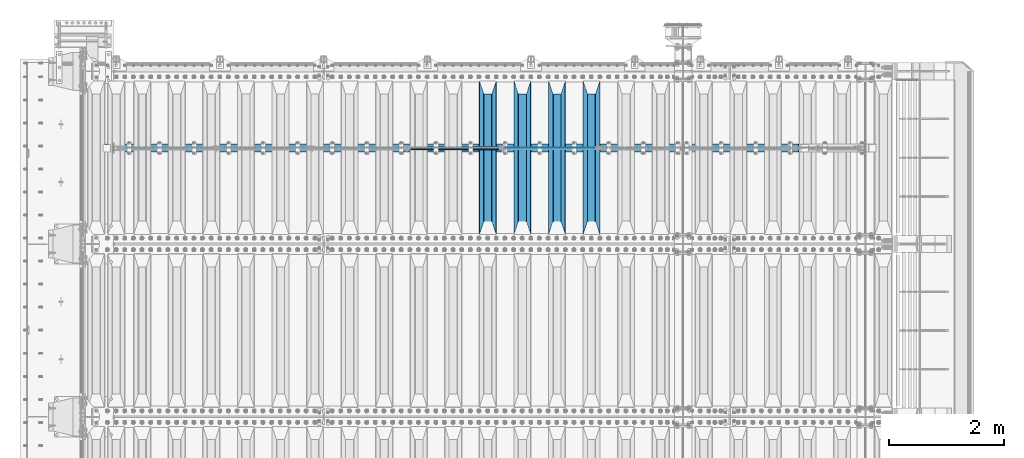
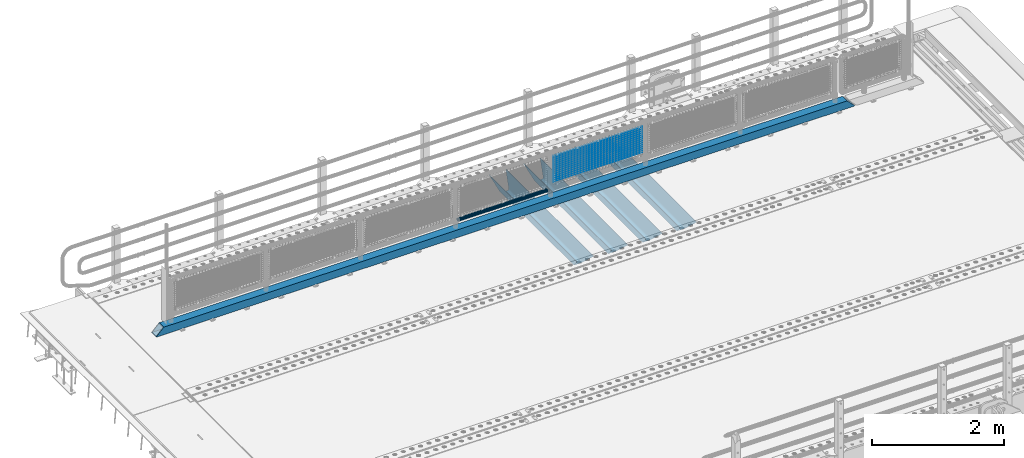
# One storey, part 113 of 219: 20 beams.
"""IFC2X3 building model written with IfcOpenShell, lengths in millimetres."""

from ifc_helpers import new_model, si_unit, frame, origin_with_axes, place, context, subcontext, project, spatial, faceted_brep, material, type_object, element, save


model = new_model("IFC2X3")

# Units and contexts
model_context = context("Model", 3, precision=1e-05, world=origin_with_axes())
body_context = subcontext(model_context, "Body", "Model", "MODEL_VIEW")
ifc_project = project(units=[si_unit("LENGTHUNIT", "METRE", prefix="MILLI"), si_unit("AREAUNIT", "SQUARE_METRE"), si_unit("VOLUMEUNIT", "CUBIC_METRE"), si_unit("MASSUNIT", "GRAM", prefix="KILO"), si_unit("TIMEUNIT", "SECOND"), si_unit("PLANEANGLEUNIT", "RADIAN"), si_unit("SOLIDANGLEUNIT", "STERADIAN"), si_unit("THERMODYNAMICTEMPERATUREUNIT", "DEGREE_CELSIUS"), si_unit("LUMINOUSINTENSITYUNIT", "LUMEN")], contexts=[model_context])

# Site, building, storey
site_placement = place(None, origin_with_axes())
site = spatial("IfcSite", under=ifc_project, at=site_placement, CompositionType="ELEMENT")
building_placement = place(site_placement, origin_with_axes())
building = spatial("IfcBuilding", under=site, at=building_placement, Name="Standard", CompositionType="ELEMENT")
storey_placement = place(building_placement, origin_with_axes())
storey = spatial("IfcBuildingStorey", under=building, at=storey_placement, Name="Undefined", CompositionType="ELEMENT", Elevation=0.0)

# Beams
ifc_material_1 = material(Name="STEEL/S355N")
beam_type_1 = type_object("IfcBeamType", PredefinedType="NOTDEFINED")
beam_1_placement = place(storey_placement, frame((8800.0, 30175.0, -115.0), z_axis=(0.0, 0.0, 1.0), x_axis=(0.0, 1.0, 0.0)))
element("IfcBeam", 1, at=beam_1_placement, inside=storey, type_object=beam_type_1, material=ifc_material_1, context=body_context, shape_type="Brep", body=[
    faceted_brep([(0.0, 150.0, 115.0), (0.0, 143.690000000001, 115.0), (2650.00000000297, 143.690000000001, 115.0), (2650.00000000297, 150.0, 115.0), (2650.00000000297, 142.0595652184, 110.000000003094), (2650.00000000297, 148.3695652184, 110.000000003094), (2441.90079219209, -80.110360073113, -98.0992078077845), (2437.7588105432, -77.5672621345566, -102.241189456673), (2434.06523489747, -74.4080125315541, -105.934765102404), (2430.9108609509, -70.7102721255742, -109.089139048974), (2428.37322971128, -66.5649389910068, -111.626770288588), (2426.51472138055, -62.0739139532889, -113.485278619323), (2425.38102192092, -57.3475956567672, -114.618978078955), (2424.99999999988, -52.5021667386536, -115.0), (2424.99999999988, 52.5021667386536, -115.0), (2425.38102192092, 57.3475956567672, -114.618978078955), (2426.51472138055, 62.0739139532889, -113.485278619323), (2428.37322971128, 66.5649389910068, -111.626770288588), (2430.9108609509, 70.7102721255742, -109.089139048974), (2434.06523489747, 74.4080125315541, -105.934765102404), (2437.7588105432, 77.5672621345566, -102.241189456673), (2441.90079219209, 80.110360073113, -98.0992078077846), (2446.38936140512, 81.9747917625791, -93.6106385947584), (2448.2494850041, 76.2713538057269, -91.7505149957729), (2444.62967112263, 74.7677798626082, -95.3703288772456), (2441.28936334127, 72.7168944282894, -98.710636658607), (2438.31067330439, 70.1691124903828, -101.689326695487), (2435.76682334748, 67.1870637758839, -104.233176652398), (2433.72034654134, 63.8440531834913, -106.279653458539), (2432.22154950042, 60.2222587982342, -107.778450499454), (2431.30727574265, 56.4107117849107, -108.692724257221), (2430.99999999987, 52.5031078186894, -109.0), (2430.99999999987, -52.5031078186894, -109.0), (2431.30727574265, -56.4107117849107, -108.692724257221), (2432.22154950042, -60.2222587982342, -107.778450499454), (2433.72034654134, -63.8440531834913, -106.279653458539), (2435.76682334748, -67.1870637758839, -104.233176652398), (2438.31067330439, -70.1691124903828, -101.689326695487), (2441.28936334127, -72.7168944282894, -98.7106366586071), (2444.62967112263, -74.7677798626082, -95.3703288772457), (2448.2494850041, -76.2713538057269, -91.7505149957729), (2650.00000000297, -142.0595652184, 110.000000003094), (2650.00000000297, -148.3695652184, 110.000000003094), (2446.38936140512, -81.9747917625791, -93.6106385947584), (2650.00000000297, -143.690000000001, 115.0), (2650.00000000297, -150.0, 115.0), (0.0, -143.690000000001, 115.0), (0.0, -150.0, 115.0), (0.0, -148.369565218261, 110.000000002667), (203.610638597427, -81.9747917625791, -93.6106385947584), (208.09920781045, -80.110360073113, -98.0992078077845), (212.241189459342, -77.5672621345566, -102.241189456673), (215.93476510507, -74.4080125315541, -105.934765102404), (219.089139051641, -70.7102721255742, -109.089139048974), (221.626770291256, -66.5649389910068, -111.626770288588), (223.485278621989, -62.0739139532889, -113.485278619323), (224.618978081624, -57.3475956567672, -114.618978078955), (225.000000002663, -52.5021667386536, -115.0), (225.000000002663, 52.5021667386536, -115.0), (224.618978081624, 57.3475956567672, -114.618978078955), (223.485278621989, 62.0739139532889, -113.485278619323), (221.626770291256, 66.5649389910068, -111.626770288588), (219.089139051641, 70.7102721255742, -109.089139048974), (215.93476510507, 74.4080125315541, -105.934765102404), (212.241189459342, 77.5672621345566, -102.241189456673), (208.09920781045, 80.110360073113, -98.0992078077846), (203.610638597427, 81.9747917625791, -93.6106385947584), (0.0, 148.369565218261, 110.000000002667), (0.0, 142.059565218262, 110.000000002667), (201.750514998439, 76.2713538057269, -91.7505149957729), (205.370328879915, 74.7677798626082, -95.3703288772456), (208.710636661275, 72.7168944282894, -98.710636658607), (211.689326698157, 70.1691124903828, -101.689326695487), (214.233176655063, 67.1870637758839, -104.233176652398), (216.279653461206, 63.8440531834913, -106.279653458539), (217.778450502123, 60.2222587982342, -107.778450499454), (218.69272425989, 56.4107117849107, -108.692724257221), (219.00000000267, 52.5031078186894, -109.0), (219.00000000267, -52.5031078186894, -109.0), (218.69272425989, -56.4107117849107, -108.692724257221), (217.778450502123, -60.2222587982342, -107.778450499454), (216.279653461206, -63.8440531834913, -106.279653458539), (214.233176655063, -67.1870637758839, -104.233176652398), (211.689326698157, -70.1691124903828, -101.689326695487), (208.710636661275, -72.7168944282894, -98.7106366586071), (205.370328879915, -74.7677798626082, -95.3703288772457), (201.750514998439, -76.2713538057269, -91.7505149957729), (0.0, -142.059565218262, 110.000000002667)], [[[0, 1, 2, 3]], [[3, 2, 4, 5]], [[6, 7, 8, 9, 10, 11, 12, 13, 14, 15, 16, 17, 18, 19, 20, 21, 22, 5, 4, 23, 24, 25, 26, 27, 28, 29, 30, 31, 32, 33, 34, 35, 36, 37, 38, 39, 40, 41, 42, 43]], [[44, 45, 42, 41]], [[46, 47, 45, 44]], [[43, 42, 45, 47, 48, 49]], [[6, 43, 49, 50]], [[7, 6, 50, 51]], [[8, 7, 51, 52]], [[9, 8, 52, 53]], [[10, 9, 53, 54]], [[11, 10, 54, 55]], [[12, 11, 55, 56]], [[13, 12, 56, 57]], [[14, 13, 57, 58]], [[15, 14, 58, 59]], [[16, 15, 59, 60]], [[17, 16, 60, 61]], [[18, 17, 61, 62]], [[19, 18, 62, 63]], [[20, 19, 63, 64]], [[21, 20, 64, 65]], [[22, 21, 65, 66]], [[0, 3, 5, 22, 66, 67]], [[1, 0, 67, 68]], [[23, 4, 2, 1, 68, 69]], [[24, 23, 69, 70]], [[25, 24, 70, 71]], [[26, 25, 71, 72]], [[27, 26, 72, 73]], [[28, 27, 73, 74]], [[29, 28, 74, 75]], [[30, 29, 75, 76]], [[31, 30, 76, 77]], [[32, 31, 77, 78]], [[33, 32, 78, 79]], [[34, 33, 79, 80]], [[35, 34, 80, 81]], [[36, 35, 81, 82]], [[37, 36, 82, 83]], [[38, 37, 83, 84]], [[39, 38, 84, 85]], [[40, 39, 85, 86]], [[46, 44, 41, 40, 86, 87]], [[47, 46, 87, 48]], [[86, 85, 84, 83, 82, 81, 80, 79, 78, 77, 76, 75, 74, 73, 72, 71, 70, 69, 68, 67, 66, 65, 64, 63, 62, 61, 60, 59, 58, 57, 56, 55, 54, 53, 52, 51, 50, 49, 48, 87]]]),
])
beam_2_placement = place(storey_placement, frame((8200.0, 30175.0, -115.0), z_axis=(0.0, 0.0, 1.0), x_axis=(0.0, 1.0, 0.0)))
element("IfcBeam", 2, at=beam_2_placement, inside=storey, type_object=beam_type_1, material=ifc_material_1, context=body_context, shape_type="Brep", body=[
    faceted_brep([(0.0, 150.0, 115.0), (0.0, 143.690000000001, 115.0), (2650.00000000297, 143.690000000001, 115.0), (2650.00000000297, 150.0, 115.0), (2650.00000000297, 142.0595652184, 110.000000003094), (2650.00000000297, 148.3695652184, 110.000000003094), (2441.90079219209, -80.110360073113, -98.0992078077845), (2437.7588105432, -77.5672621345566, -102.241189456673), (2434.06523489747, -74.4080125315541, -105.934765102404), (2430.9108609509, -70.7102721255742, -109.089139048974), (2428.37322971128, -66.5649389910068, -111.626770288588), (2426.51472138055, -62.0739139532889, -113.485278619323), (2425.38102192092, -57.3475956567672, -114.618978078955), (2424.99999999988, -52.5021667386536, -115.0), (2424.99999999988, 52.5021667386536, -115.0), (2425.38102192092, 57.3475956567672, -114.618978078955), (2426.51472138055, 62.0739139532889, -113.485278619323), (2428.37322971128, 66.5649389910068, -111.626770288588), (2430.9108609509, 70.7102721255742, -109.089139048974), (2434.06523489747, 74.4080125315541, -105.934765102404), (2437.7588105432, 77.5672621345566, -102.241189456673), (2441.90079219209, 80.110360073113, -98.0992078077846), (2446.38936140512, 81.9747917625791, -93.6106385947584), (2448.2494850041, 76.2713538057269, -91.7505149957729), (2444.62967112263, 74.7677798626082, -95.3703288772456), (2441.28936334127, 72.7168944282894, -98.710636658607), (2438.31067330439, 70.1691124903828, -101.689326695487), (2435.76682334748, 67.1870637758839, -104.233176652398), (2433.72034654134, 63.8440531834913, -106.279653458539), (2432.22154950042, 60.2222587982342, -107.778450499454), (2431.30727574265, 56.4107117849107, -108.692724257221), (2430.99999999987, 52.5031078186894, -109.0), (2430.99999999987, -52.5031078186894, -109.0), (2431.30727574265, -56.4107117849107, -108.692724257221), (2432.22154950042, -60.2222587982342, -107.778450499454), (2433.72034654134, -63.8440531834913, -106.279653458539), (2435.76682334748, -67.1870637758839, -104.233176652398), (2438.31067330439, -70.1691124903828, -101.689326695487), (2441.28936334127, -72.7168944282894, -98.7106366586071), (2444.62967112263, -74.7677798626082, -95.3703288772457), (2448.2494850041, -76.2713538057269, -91.7505149957729), (2650.00000000297, -142.0595652184, 110.000000003094), (2650.00000000297, -148.3695652184, 110.000000003094), (2446.38936140512, -81.9747917625791, -93.6106385947584), (2650.00000000297, -143.690000000001, 115.0), (2650.00000000297, -150.0, 115.0), (0.0, -143.690000000001, 115.0), (0.0, -150.0, 115.0), (0.0, -148.369565218261, 110.000000002667), (203.610638597427, -81.9747917625791, -93.6106385947584), (208.09920781045, -80.110360073113, -98.0992078077845), (212.241189459342, -77.5672621345566, -102.241189456673), (215.93476510507, -74.4080125315541, -105.934765102404), (219.089139051641, -70.7102721255742, -109.089139048974), (221.626770291256, -66.5649389910068, -111.626770288588), (223.485278621989, -62.0739139532889, -113.485278619323), (224.618978081624, -57.3475956567672, -114.618978078955), (225.000000002663, -52.5021667386536, -115.0), (225.000000002663, 52.5021667386536, -115.0), (224.618978081624, 57.3475956567672, -114.618978078955), (223.485278621989, 62.0739139532889, -113.485278619323), (221.626770291256, 66.5649389910068, -111.626770288588), (219.089139051641, 70.7102721255742, -109.089139048974), (215.93476510507, 74.4080125315541, -105.934765102404), (212.241189459342, 77.5672621345566, -102.241189456673), (208.09920781045, 80.110360073113, -98.0992078077846), (203.610638597427, 81.9747917625791, -93.6106385947584), (0.0, 148.369565218261, 110.000000002667), (0.0, 142.059565218262, 110.000000002667), (201.750514998439, 76.2713538057269, -91.7505149957729), (205.370328879915, 74.7677798626082, -95.3703288772456), (208.710636661275, 72.7168944282894, -98.710636658607), (211.689326698157, 70.1691124903828, -101.689326695487), (214.233176655063, 67.1870637758839, -104.233176652398), (216.279653461206, 63.8440531834913, -106.279653458539), (217.778450502123, 60.2222587982342, -107.778450499454), (218.69272425989, 56.4107117849107, -108.692724257221), (219.00000000267, 52.5031078186894, -109.0), (219.00000000267, -52.5031078186894, -109.0), (218.69272425989, -56.4107117849107, -108.692724257221), (217.778450502123, -60.2222587982342, -107.778450499454), (216.279653461206, -63.8440531834913, -106.279653458539), (214.233176655063, -67.1870637758839, -104.233176652398), (211.689326698157, -70.1691124903828, -101.689326695487), (208.710636661275, -72.7168944282894, -98.7106366586071), (205.370328879915, -74.7677798626082, -95.3703288772457), (201.750514998439, -76.2713538057269, -91.7505149957729), (0.0, -142.059565218262, 110.000000002667)], [[[0, 1, 2, 3]], [[3, 2, 4, 5]], [[6, 7, 8, 9, 10, 11, 12, 13, 14, 15, 16, 17, 18, 19, 20, 21, 22, 5, 4, 23, 24, 25, 26, 27, 28, 29, 30, 31, 32, 33, 34, 35, 36, 37, 38, 39, 40, 41, 42, 43]], [[44, 45, 42, 41]], [[46, 47, 45, 44]], [[43, 42, 45, 47, 48, 49]], [[6, 43, 49, 50]], [[7, 6, 50, 51]], [[8, 7, 51, 52]], [[9, 8, 52, 53]], [[10, 9, 53, 54]], [[11, 10, 54, 55]], [[12, 11, 55, 56]], [[13, 12, 56, 57]], [[14, 13, 57, 58]], [[15, 14, 58, 59]], [[16, 15, 59, 60]], [[17, 16, 60, 61]], [[18, 17, 61, 62]], [[19, 18, 62, 63]], [[20, 19, 63, 64]], [[21, 20, 64, 65]], [[22, 21, 65, 66]], [[0, 3, 5, 22, 66, 67]], [[1, 0, 67, 68]], [[23, 4, 2, 1, 68, 69]], [[24, 23, 69, 70]], [[25, 24, 70, 71]], [[26, 25, 71, 72]], [[27, 26, 72, 73]], [[28, 27, 73, 74]], [[29, 28, 74, 75]], [[30, 29, 75, 76]], [[31, 30, 76, 77]], [[32, 31, 77, 78]], [[33, 32, 78, 79]], [[34, 33, 79, 80]], [[35, 34, 80, 81]], [[36, 35, 81, 82]], [[37, 36, 82, 83]], [[38, 37, 83, 84]], [[39, 38, 84, 85]], [[40, 39, 85, 86]], [[46, 44, 41, 40, 86, 87]], [[47, 46, 87, 48]], [[86, 85, 84, 83, 82, 81, 80, 79, 78, 77, 76, 75, 74, 73, 72, 71, 70, 69, 68, 67, 66, 65, 64, 63, 62, 61, 60, 59, 58, 57, 56, 55, 54, 53, 52, 51, 50, 49, 48, 87]]]),
])
beam_3_placement = place(storey_placement, frame((7600.0, 30175.0, -115.0), z_axis=(0.0, 0.0, 1.0), x_axis=(0.0, 1.0, 0.0)))
element("IfcBeam", 3, at=beam_3_placement, inside=storey, type_object=beam_type_1, material=ifc_material_1, context=body_context, shape_type="Brep", body=[
    faceted_brep([(0.0, 150.0, 115.0), (0.0, 143.690000000001, 115.0), (2650.00000000297, 143.690000000001, 115.0), (2650.00000000297, 150.0, 115.0), (2650.00000000297, 142.0595652184, 110.000000003094), (2650.00000000297, 148.3695652184, 110.000000003094), (2441.90079219209, -80.110360073113, -98.0992078077845), (2437.7588105432, -77.5672621345566, -102.241189456673), (2434.06523489747, -74.4080125315541, -105.934765102404), (2430.9108609509, -70.7102721255742, -109.089139048974), (2428.37322971128, -66.5649389910068, -111.626770288588), (2426.51472138055, -62.0739139532889, -113.485278619323), (2425.38102192092, -57.3475956567672, -114.618978078955), (2424.99999999988, -52.5021667386536, -115.0), (2424.99999999988, 52.5021667386536, -115.0), (2425.38102192092, 57.3475956567672, -114.618978078955), (2426.51472138055, 62.0739139532889, -113.485278619323), (2428.37322971128, 66.5649389910068, -111.626770288588), (2430.9108609509, 70.7102721255742, -109.089139048974), (2434.06523489747, 74.4080125315541, -105.934765102404), (2437.7588105432, 77.5672621345566, -102.241189456673), (2441.90079219209, 80.110360073113, -98.0992078077846), (2446.38936140512, 81.9747917625791, -93.6106385947584), (2448.2494850041, 76.2713538057269, -91.7505149957729), (2444.62967112263, 74.7677798626082, -95.3703288772456), (2441.28936334127, 72.7168944282894, -98.710636658607), (2438.31067330439, 70.1691124903828, -101.689326695487), (2435.76682334748, 67.1870637758839, -104.233176652398), (2433.72034654134, 63.8440531834913, -106.279653458539), (2432.22154950042, 60.2222587982342, -107.778450499454), (2431.30727574265, 56.4107117849107, -108.692724257221), (2430.99999999987, 52.5031078186894, -109.0), (2430.99999999987, -52.5031078186894, -109.0), (2431.30727574265, -56.4107117849107, -108.692724257221), (2432.22154950042, -60.2222587982342, -107.778450499454), (2433.72034654134, -63.8440531834913, -106.279653458539), (2435.76682334748, -67.1870637758839, -104.233176652398), (2438.31067330439, -70.1691124903828, -101.689326695487), (2441.28936334127, -72.7168944282894, -98.7106366586071), (2444.62967112263, -74.7677798626082, -95.3703288772457), (2448.2494850041, -76.2713538057269, -91.7505149957729), (2650.00000000297, -142.0595652184, 110.000000003094), (2650.00000000297, -148.3695652184, 110.000000003094), (2446.38936140512, -81.9747917625791, -93.6106385947584), (2650.00000000297, -143.690000000001, 115.0), (2650.00000000297, -150.0, 115.0), (0.0, -143.690000000001, 115.0), (0.0, -150.0, 115.0), (0.0, -148.369565218261, 110.000000002667), (203.610638597427, -81.9747917625791, -93.6106385947584), (208.09920781045, -80.110360073113, -98.0992078077845), (212.241189459342, -77.5672621345566, -102.241189456673), (215.93476510507, -74.4080125315541, -105.934765102404), (219.089139051641, -70.7102721255742, -109.089139048974), (221.626770291256, -66.5649389910068, -111.626770288588), (223.485278621989, -62.0739139532889, -113.485278619323), (224.618978081624, -57.3475956567672, -114.618978078955), (225.000000002663, -52.5021667386536, -115.0), (225.000000002663, 52.5021667386536, -115.0), (224.618978081624, 57.3475956567672, -114.618978078955), (223.485278621989, 62.0739139532889, -113.485278619323), (221.626770291256, 66.5649389910068, -111.626770288588), (219.089139051641, 70.7102721255742, -109.089139048974), (215.93476510507, 74.4080125315541, -105.934765102404), (212.241189459342, 77.5672621345566, -102.241189456673), (208.09920781045, 80.110360073113, -98.0992078077846), (203.610638597427, 81.9747917625791, -93.6106385947584), (0.0, 148.369565218261, 110.000000002667), (0.0, 142.059565218262, 110.000000002667), (201.750514998439, 76.2713538057269, -91.7505149957729), (205.370328879915, 74.7677798626082, -95.3703288772456), (208.710636661275, 72.7168944282894, -98.710636658607), (211.689326698157, 70.1691124903828, -101.689326695487), (214.233176655063, 67.1870637758839, -104.233176652398), (216.279653461206, 63.8440531834913, -106.279653458539), (217.778450502123, 60.2222587982342, -107.778450499454), (218.69272425989, 56.4107117849107, -108.692724257221), (219.00000000267, 52.5031078186894, -109.0), (219.00000000267, -52.5031078186894, -109.0), (218.69272425989, -56.4107117849107, -108.692724257221), (217.778450502123, -60.2222587982342, -107.778450499454), (216.279653461206, -63.8440531834913, -106.279653458539), (214.233176655063, -67.1870637758839, -104.233176652398), (211.689326698157, -70.1691124903828, -101.689326695487), (208.710636661275, -72.7168944282894, -98.7106366586071), (205.370328879915, -74.7677798626082, -95.3703288772457), (201.750514998439, -76.2713538057269, -91.7505149957729), (0.0, -142.059565218262, 110.000000002667)], [[[0, 1, 2, 3]], [[3, 2, 4, 5]], [[6, 7, 8, 9, 10, 11, 12, 13, 14, 15, 16, 17, 18, 19, 20, 21, 22, 5, 4, 23, 24, 25, 26, 27, 28, 29, 30, 31, 32, 33, 34, 35, 36, 37, 38, 39, 40, 41, 42, 43]], [[44, 45, 42, 41]], [[46, 47, 45, 44]], [[43, 42, 45, 47, 48, 49]], [[6, 43, 49, 50]], [[7, 6, 50, 51]], [[8, 7, 51, 52]], [[9, 8, 52, 53]], [[10, 9, 53, 54]], [[11, 10, 54, 55]], [[12, 11, 55, 56]], [[13, 12, 56, 57]], [[14, 13, 57, 58]], [[15, 14, 58, 59]], [[16, 15, 59, 60]], [[17, 16, 60, 61]], [[18, 17, 61, 62]], [[19, 18, 62, 63]], [[20, 19, 63, 64]], [[21, 20, 64, 65]], [[22, 21, 65, 66]], [[0, 3, 5, 22, 66, 67]], [[1, 0, 67, 68]], [[23, 4, 2, 1, 68, 69]], [[24, 23, 69, 70]], [[25, 24, 70, 71]], [[26, 25, 71, 72]], [[27, 26, 72, 73]], [[28, 27, 73, 74]], [[29, 28, 74, 75]], [[30, 29, 75, 76]], [[31, 30, 76, 77]], [[32, 31, 77, 78]], [[33, 32, 78, 79]], [[34, 33, 79, 80]], [[35, 34, 80, 81]], [[36, 35, 81, 82]], [[37, 36, 82, 83]], [[38, 37, 83, 84]], [[39, 38, 84, 85]], [[40, 39, 85, 86]], [[46, 44, 41, 40, 86, 87]], [[47, 46, 87, 48]], [[86, 85, 84, 83, 82, 81, 80, 79, 78, 77, 76, 75, 74, 73, 72, 71, 70, 69, 68, 67, 66, 65, 64, 63, 62, 61, 60, 59, 58, 57, 56, 55, 54, 53, 52, 51, 50, 49, 48, 87]]]),
])
beam_4_placement = place(storey_placement, frame((7000.0, 30175.0, -115.0), z_axis=(0.0, 0.0, 1.0), x_axis=(0.0, 1.0, 0.0)))
element("IfcBeam", 4, at=beam_4_placement, inside=storey, type_object=beam_type_1, material=ifc_material_1, context=body_context, shape_type="Brep", body=[
    faceted_brep([(0.0, 150.0, 115.0), (0.0, 143.690000000001, 115.0), (2650.00000000297, 143.690000000001, 115.0), (2650.00000000297, 150.0, 115.0), (2650.00000000297, 142.0595652184, 110.000000003094), (2650.00000000297, 148.3695652184, 110.000000003094), (2441.90079219209, -80.110360073113, -98.0992078077845), (2437.7588105432, -77.5672621345566, -102.241189456673), (2434.06523489747, -74.4080125315541, -105.934765102404), (2430.9108609509, -70.7102721255742, -109.089139048974), (2428.37322971128, -66.5649389910068, -111.626770288588), (2426.51472138055, -62.0739139532889, -113.485278619323), (2425.38102192092, -57.3475956567672, -114.618978078955), (2424.99999999988, -52.5021667386536, -115.0), (2424.99999999988, 52.5021667386536, -115.0), (2425.38102192092, 57.3475956567672, -114.618978078955), (2426.51472138055, 62.0739139532889, -113.485278619323), (2428.37322971128, 66.5649389910068, -111.626770288588), (2430.9108609509, 70.7102721255742, -109.089139048974), (2434.06523489747, 74.4080125315541, -105.934765102404), (2437.7588105432, 77.5672621345566, -102.241189456673), (2441.90079219209, 80.110360073113, -98.0992078077846), (2446.38936140512, 81.9747917625791, -93.6106385947584), (2448.2494850041, 76.2713538057269, -91.7505149957729), (2444.62967112263, 74.7677798626082, -95.3703288772456), (2441.28936334127, 72.7168944282894, -98.710636658607), (2438.31067330439, 70.1691124903828, -101.689326695487), (2435.76682334748, 67.1870637758839, -104.233176652398), (2433.72034654134, 63.8440531834913, -106.279653458539), (2432.22154950042, 60.2222587982342, -107.778450499454), (2431.30727574265, 56.4107117849107, -108.692724257221), (2430.99999999987, 52.5031078186894, -109.0), (2430.99999999987, -52.5031078186894, -109.0), (2431.30727574265, -56.4107117849107, -108.692724257221), (2432.22154950042, -60.2222587982342, -107.778450499454), (2433.72034654134, -63.8440531834913, -106.279653458539), (2435.76682334748, -67.1870637758839, -104.233176652398), (2438.31067330439, -70.1691124903828, -101.689326695487), (2441.28936334127, -72.7168944282894, -98.7106366586071), (2444.62967112263, -74.7677798626082, -95.3703288772457), (2448.2494850041, -76.2713538057269, -91.7505149957729), (2650.00000000297, -142.0595652184, 110.000000003094), (2650.00000000297, -148.3695652184, 110.000000003094), (2446.38936140512, -81.9747917625791, -93.6106385947584), (2650.00000000297, -143.690000000001, 115.0), (2650.00000000297, -150.0, 115.0), (0.0, -143.690000000001, 115.0), (0.0, -150.0, 115.0), (0.0, -148.369565218261, 110.000000002667), (203.610638597427, -81.9747917625791, -93.6106385947584), (208.09920781045, -80.110360073113, -98.0992078077845), (212.241189459342, -77.5672621345566, -102.241189456673), (215.93476510507, -74.4080125315541, -105.934765102404), (219.089139051641, -70.7102721255742, -109.089139048974), (221.626770291256, -66.5649389910068, -111.626770288588), (223.485278621989, -62.0739139532889, -113.485278619323), (224.618978081624, -57.3475956567672, -114.618978078955), (225.000000002663, -52.5021667386536, -115.0), (225.000000002663, 52.5021667386536, -115.0), (224.618978081624, 57.3475956567672, -114.618978078955), (223.485278621989, 62.0739139532889, -113.485278619323), (221.626770291256, 66.5649389910068, -111.626770288588), (219.089139051641, 70.7102721255742, -109.089139048974), (215.93476510507, 74.4080125315541, -105.934765102404), (212.241189459342, 77.5672621345566, -102.241189456673), (208.09920781045, 80.110360073113, -98.0992078077846), (203.610638597427, 81.9747917625791, -93.6106385947584), (0.0, 148.369565218261, 110.000000002667), (0.0, 142.059565218262, 110.000000002667), (201.750514998439, 76.2713538057269, -91.7505149957729), (205.370328879915, 74.7677798626082, -95.3703288772456), (208.710636661275, 72.7168944282894, -98.710636658607), (211.689326698157, 70.1691124903828, -101.689326695487), (214.233176655063, 67.1870637758839, -104.233176652398), (216.279653461206, 63.8440531834913, -106.279653458539), (217.778450502123, 60.2222587982342, -107.778450499454), (218.69272425989, 56.4107117849107, -108.692724257221), (219.00000000267, 52.5031078186894, -109.0), (219.00000000267, -52.5031078186894, -109.0), (218.69272425989, -56.4107117849107, -108.692724257221), (217.778450502123, -60.2222587982342, -107.778450499454), (216.279653461206, -63.8440531834913, -106.279653458539), (214.233176655063, -67.1870637758839, -104.233176652398), (211.689326698157, -70.1691124903828, -101.689326695487), (208.710636661275, -72.7168944282894, -98.7106366586071), (205.370328879915, -74.7677798626082, -95.3703288772457), (201.750514998439, -76.2713538057269, -91.7505149957729), (0.0, -142.059565218262, 110.000000002667)], [[[0, 1, 2, 3]], [[3, 2, 4, 5]], [[6, 7, 8, 9, 10, 11, 12, 13, 14, 15, 16, 17, 18, 19, 20, 21, 22, 5, 4, 23, 24, 25, 26, 27, 28, 29, 30, 31, 32, 33, 34, 35, 36, 37, 38, 39, 40, 41, 42, 43]], [[44, 45, 42, 41]], [[46, 47, 45, 44]], [[43, 42, 45, 47, 48, 49]], [[6, 43, 49, 50]], [[7, 6, 50, 51]], [[8, 7, 51, 52]], [[9, 8, 52, 53]], [[10, 9, 53, 54]], [[11, 10, 54, 55]], [[12, 11, 55, 56]], [[13, 12, 56, 57]], [[14, 13, 57, 58]], [[15, 14, 58, 59]], [[16, 15, 59, 60]], [[17, 16, 60, 61]], [[18, 17, 61, 62]], [[19, 18, 62, 63]], [[20, 19, 63, 64]], [[21, 20, 64, 65]], [[22, 21, 65, 66]], [[0, 3, 5, 22, 66, 67]], [[1, 0, 67, 68]], [[23, 4, 2, 1, 68, 69]], [[24, 23, 69, 70]], [[25, 24, 70, 71]], [[26, 25, 71, 72]], [[27, 26, 72, 73]], [[28, 27, 73, 74]], [[29, 28, 74, 75]], [[30, 29, 75, 76]], [[31, 30, 76, 77]], [[32, 31, 77, 78]], [[33, 32, 78, 79]], [[34, 33, 79, 80]], [[35, 34, 80, 81]], [[36, 35, 81, 82]], [[37, 36, 82, 83]], [[38, 37, 83, 84]], [[39, 38, 84, 85]], [[40, 39, 85, 86]], [[46, 44, 41, 40, 86, 87]], [[47, 46, 87, 48]], [[86, 85, 84, 83, 82, 81, 80, 79, 78, 77, 76, 75, 74, 73, 72, 71, 70, 69, 68, 67, 66, 65, 64, 63, 62, 61, 60, 59, 58, 57, 56, 55, 54, 53, 52, 51, 50, 49, 48, 87]]]),
])
ifc_material_2 = material(Name="Misc_Undefined")
beam_type_2 = type_object("IfcBeamType", Name="D3", PredefinedType="NOTDEFINED")
for number, where, z_axis, x_axis in (
    (5, (7308.0, 31670.5, 851.597), (0.0, 0.0, 1.0), (1.0, 0.0, 0.0)),
    (6, (7308.0, 31670.5, 669.452000000001), (0.0, 0.0, 1.0), (1.0, 0.0, 0.0)),
    (7, (7308.0, 31670.5, 523.736000000001), (0.0, 0.0, 1.0), (1.0, 0.0, 0.0)),
    (8, (7308.0, 31670.5, 487.307000000001), (0.0, 0.0, 1.0), (1.0, 0.0, 0.0)),
    (9, (7308.0, 31670.5, 705.881000000001), (0.0, 0.0, 1.0), (1.0, 0.0, 0.0)),
    (10, (7308.0, 31670.5, 596.594000000001), (0.0, 0.0, 1.0), (1.0, 0.0, 0.0)),
    (11, (7308.0, 31670.5, 450.878000000001), (0.0, 0.0, 1.0), (1.0, 0.0, 0.0)),
    (12, (7308.0, 31670.5, 815.168000000001), (0.0, 0.0, 1.0), (1.0, 0.0, 0.0)),
    (13, (7308.0, 31670.5, 888.026000000001), (0.0, 0.0, 1.0), (1.0, 0.0, 0.0)),
    (14, (7308.0, 31670.5, 778.739000000001), (0.0, 0.0, 1.0), (1.0, 0.0, 0.0)),
    (15, (7308.0, 31670.5, 742.310000000001), (0.0, 0.0, 1.0), (1.0, 0.0, 0.0)),
    (16, (7308.0, 31670.5, 633.023000000001), (0.0, 0.0, 1.0), (1.0, 0.0, 0.0)),
    (17, (7308.0, 31670.5, 560.165000000001), (0.0, 0.0, 1.0), (1.0, 0.0, 0.0)),
    (18, (7308.0, 31670.5, 414.449000000001), (0.0, 0.0, 1.0), (1.0, 0.0, 0.0)),
):
    element("IfcBeam", number, at=place(storey_placement, frame(where, z_axis=z_axis, x_axis=x_axis)), inside=storey, type_object=beam_type_2, material=ifc_material_2, ObjectType="D3", context=body_context, shape_type="Brep", body=[
        faceted_brep([(0.0, -1.5, -5.6843418860808e-14), (0.0, -0.75, -1.29903810567669), (1548.0, -0.75, -1.29903810567669), (1548.0, -1.5, 0.0), (0.0, 0.75, -1.29903810567669), (1548.0, 0.75, -1.29903810567669), (0.0, 1.5, -5.6843418860808e-14), (1548.0, 1.5, 0.0), (0.0, 0.75, 1.29903810567669), (1548.0, 0.75, 1.29903810567669), (0.0, -0.75, 1.29903810567669), (1548.0, -0.75, 1.29903810567669)], [[[0, 1, 2, 3]], [[1, 4, 5, 2]], [[4, 6, 7, 5]], [[6, 8, 9, 7]], [[8, 10, 11, 9]], [[10, 0, 3, 11]], [[5, 7, 9, 11, 3, 2]], [[10, 8, 6, 4, 1, 0]]]),
    ])
ifc_material_3 = material()
beam_type_3 = type_object("IfcBeamType", PredefinedType="NOTDEFINED")
beam_5_placement = place(storey_placement, frame((5629.85000000001, 31664.5, 298.170000000002), z_axis=(0.0, 0.0, 1.0), x_axis=(1.0, 0.0, 0.0)))
element("IfcBeam", 19, at=beam_5_placement, inside=storey, type_object=beam_type_3, material=ifc_material_3, context=body_context, shape_type="Brep", body=[
    faceted_brep([(0.0, -25.3499999999985, 0.0), (0.0, -23.4203461491597, 9.70102501045585), (1588.0, -23.4203461491597, 9.70102501045506), (1588.0, -25.3499999999985, 0.0), (0.0, -17.9251569030785, 17.9251569030785), (1588.0, -17.9251569030785, 17.925156903079), (0.0, -9.70102501045403, 23.4203461491616), (1588.0, -9.70102501045403, 23.4203461491611), (0.0, 0.0, 25.3500000000004), (1588.0, 0.0, 25.35), (0.0, 9.70102501045403, 23.4203461491616), (1588.0, 9.70102501045403, 23.4203461491611), (0.0, 17.9251569030785, 17.9251569030785), (1588.0, 17.9251569030785, 17.925156903079), (0.0, 23.4203461491597, 9.70102501045585), (1588.0, 23.4203461491597, 9.70102501045506), (0.0, 25.3499999999985, 0.0), (1588.0, 25.3499999999985, 0.0), (0.0, 23.4203461491597, -9.70102501045585), (1588.0, 23.4203461491597, -9.70102501045506), (0.0, 17.9251569030785, -17.9251569030785), (1588.0, 17.9251569030785, -17.925156903079), (0.0, 9.70102501045403, -23.4203461491616), (1588.0, 9.70102501045403, -23.4203461491611), (0.0, 0.0, -25.3500000000004), (1588.0, 0.0, -25.35), (0.0, -9.70102501045403, -23.4203461491616), (1588.0, -9.70102501045403, -23.4203461491611), (0.0, -17.9251569030785, -17.9251569030785), (1588.0, -17.9251569030785, -17.925156903079), (0.0, -23.4203461491597, -9.70102501045585), (1588.0, -23.4203461491597, -9.70102501045506), (0.0, -30.1500000000015, 0.0), (0.0, -27.8549679052157, -11.5379054858076), (1588.0, -27.8549679052157, -11.5379054858075), (1588.0, -30.1500000000015, 0.0), (0.0, -21.3192694527752, -21.3192694527752), (1588.0, -21.3192694527752, -21.3192694527744), (0.0, -11.5379054858058, -27.8549679052157), (1588.0, -11.5379054858058, -27.8549679052153), (0.0, 0.0, -30.1499999999996), (1588.0, 0.0, -30.15), (0.0, 11.5379054858058, -27.8549679052157), (1588.0, 11.5379054858058, -27.8549679052153), (0.0, 21.3192694527752, -21.3192694527752), (1588.0, 21.3192694527752, -21.3192694527744), (0.0, 27.8549679052157, -11.5379054858076), (1588.0, 27.8549679052157, -11.5379054858074), (0.0, 30.1500000000015, 0.0), (1588.0, 30.1500000000015, 0.0), (0.0, 27.8549679052157, 11.5379054858076), (1588.0, 27.8549679052157, 11.5379054858074), (0.0, 21.3192694527752, 21.3192694527752), (1588.0, 21.3192694527752, 21.3192694527744), (0.0, 11.5379054858058, 27.8549679052157), (1588.0, 11.5379054858058, 27.8549679052153), (0.0, 0.0, 30.1499999999996), (1588.0, 0.0, 30.15), (0.0, -11.5379054858058, 27.8549679052157), (1588.0, -11.5379054858058, 27.8549679052153), (0.0, -21.3192694527752, 21.3192694527752), (1588.0, -21.3192694527752, 21.3192694527744), (0.0, -27.8549679052157, 11.5379054858076), (1588.0, -27.8549679052157, 11.5379054858074)], [[[0, 1, 2, 3]], [[1, 4, 5, 2]], [[4, 6, 7, 5]], [[6, 8, 9, 7]], [[8, 10, 11, 9]], [[10, 12, 13, 11]], [[12, 14, 15, 13]], [[14, 16, 17, 15]], [[16, 18, 19, 17]], [[18, 20, 21, 19]], [[20, 22, 23, 21]], [[22, 24, 25, 23]], [[24, 26, 27, 25]], [[26, 28, 29, 27]], [[28, 30, 31, 29]], [[30, 0, 3, 31]], [[32, 33, 34, 35]], [[33, 36, 37, 34]], [[36, 38, 39, 37]], [[38, 40, 41, 39]], [[40, 42, 43, 41]], [[42, 44, 45, 43]], [[44, 46, 47, 45]], [[46, 48, 49, 47]], [[48, 50, 51, 49]], [[50, 52, 53, 51]], [[52, 54, 55, 53]], [[54, 56, 57, 55]], [[56, 58, 59, 57]], [[58, 60, 61, 59]], [[60, 62, 63, 61]], [[62, 32, 35, 63]], [[37, 39, 41, 43, 45, 47, 49, 51, 53, 55, 57, 59, 61, 63, 35, 34], [5, 7, 9, 11, 13, 15, 17, 19, 21, 23, 25, 27, 29, 31, 3, 2]], [[62, 60, 58, 56, 54, 52, 50, 48, 46, 44, 42, 40, 38, 36, 33, 32], [30, 28, 26, 24, 22, 20, 18, 16, 14, 12, 10, 8, 6, 4, 1, 0]]]),
])
beam_type_4 = type_object("IfcBeamType", PredefinedType="NOTDEFINED")
beam_6_placement = place(storey_placement, frame((325.0, 31664.5, 98.0199999999977), z_axis=(0.0, 0.0, 1.0), x_axis=(1.0, 0.0, 0.0)))
element("IfcBeam", 20, at=beam_6_placement, inside=storey, type_object=beam_type_4, material=ifc_material_3, context=body_context, shape_type="Brep", body=[
    faceted_brep([(0.0, -70.0, -70.0), (0.0, 70.0, -70.0), (12202.0, 70.0, -70.0), (12202.0, -70.0, -70.0), (12071.8884698478, -70.0, 70.0), (12071.8884698478, 70.0, 70.0), (130.111530936145, 70.0, 70.0), (130.111528976142, -70.0, 70.0), (12202.0, -70.0, -60.0079600980693), (0.0, -70.0, -60.0079591069113), (12081.8964362873, -60.0, 60.0), (12202.0, -60.0, -60.0), (0.0, -60.0, -60.0), (120.103562690862, -60.0, 60.0), (12081.8964362873, 60.0, 60.0), (120.10356437086, 60.0, 60.0), (12202.0, 60.0, -60.0), (0.0, 60.0, -60.0), (12202.0, 70.0, -60.0079600980693), (0.0, 70.0, -60.0079610653512)], [[[0, 1, 2, 3]], [[4, 5, 6, 7]], [[0, 3, 8, 4, 7, 9]], [[10, 11, 12, 13]], [[14, 10, 13, 15]], [[16, 14, 15, 17]], [[4, 8, 11, 10, 14, 16, 18, 5]], [[11, 8, 3, 2, 18, 16]], [[17, 12, 11, 16]], [[1, 0, 9, 12, 17, 19]], [[5, 18, 2, 1, 19, 6]], [[17, 15, 13, 12, 9, 7, 6, 19]]]),
])

save(model, "model.ifc")
